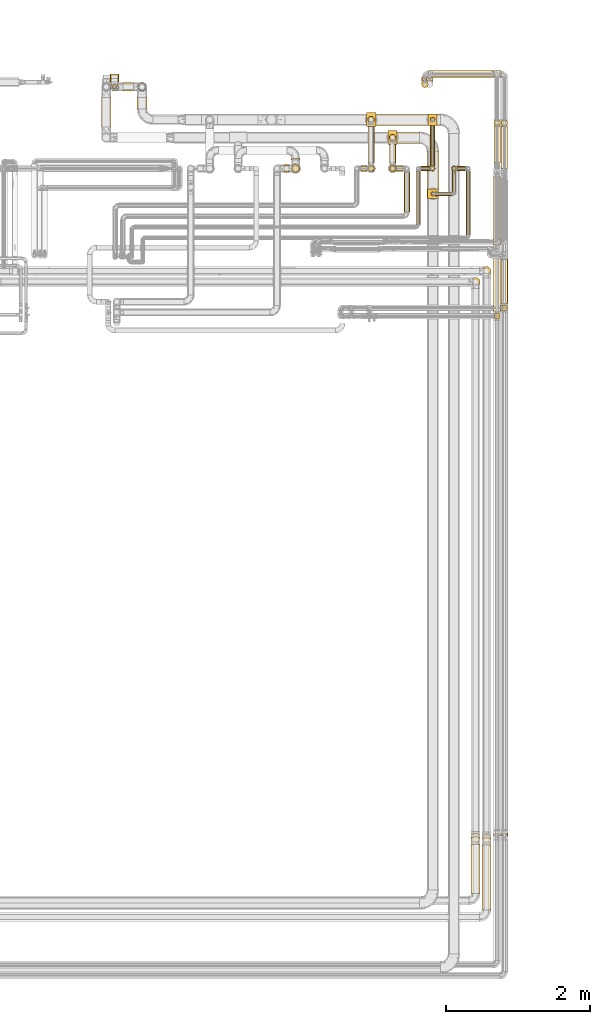
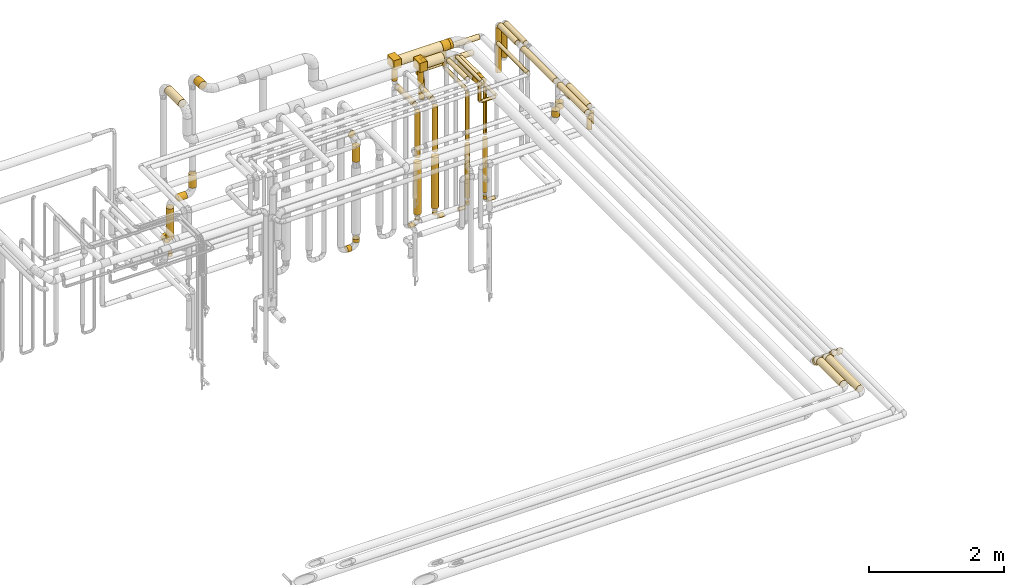
# One storey, part 18 of 824: 70 coverings.
"""IFC2X3 building model written with IfcOpenShell, lengths in millimetres."""

from ifc_helpers import new_model, entity, si_unit, converted_unit, derived_unit, direction, frame, frame_2d, origin, origin_2d_with_axis, place, context, subcontext, project, spatial, polyline, circle_curve, parameter, trimmed, segment, composite_curve, rectangle, circle, outline, extrude, element, save


model = new_model("IFC2X3")

# Units and contexts
model_context = context("Model", 3, precision=0.01, world=origin(), true_north=direction((6.12303176911189e-17, 1.0)))
body_context = subcontext(model_context, "Body", "Model", "MODEL_VIEW")
ifc_project = project(units=[si_unit("LENGTHUNIT", "METRE", prefix="MILLI"), si_unit("AREAUNIT", "SQUARE_METRE"), si_unit("VOLUMEUNIT", "CUBIC_METRE"), converted_unit("PLANEANGLEUNIT", "DEGREE", entity("IfcRatioMeasure", 0.0174532925199433), si_unit("PLANEANGLEUNIT", "RADIAN"), dimensions=[0, 0, 0, 0, 0, 0, 0]), si_unit("MASSUNIT", "GRAM", prefix="KILO"), derived_unit("MASSDENSITYUNIT", [(si_unit("MASSUNIT", "GRAM", prefix="KILO"), 1), (si_unit("LENGTHUNIT", "METRE"), -3)]), derived_unit("MOMENTOFINERTIAUNIT", [(si_unit("LENGTHUNIT", "METRE"), 4)]), si_unit("TIMEUNIT", "SECOND"), si_unit("FREQUENCYUNIT", "HERTZ"), si_unit("THERMODYNAMICTEMPERATUREUNIT", "DEGREE_CELSIUS"), derived_unit("THERMALTRANSMITTANCEUNIT", [(si_unit("MASSUNIT", "GRAM", prefix="KILO"), 1), (si_unit("THERMODYNAMICTEMPERATUREUNIT", "KELVIN"), -1), (si_unit("TIMEUNIT", "SECOND"), -3)]), derived_unit("VOLUMETRICFLOWRATEUNIT", [(si_unit("LENGTHUNIT", "METRE"), 3), (si_unit("TIMEUNIT", "SECOND"), -1)]), derived_unit("MASSFLOWRATEUNIT", [(si_unit("MASSUNIT", "GRAM", prefix="KILO"), 1), (si_unit("TIMEUNIT", "SECOND"), -1)]), derived_unit("ROTATIONALFREQUENCYUNIT", [(si_unit("TIMEUNIT", "SECOND"), -1)]), si_unit("ELECTRICCURRENTUNIT", "AMPERE"), si_unit("ELECTRICVOLTAGEUNIT", "VOLT"), si_unit("POWERUNIT", "WATT"), si_unit("FORCEUNIT", "NEWTON", prefix="KILO"), si_unit("ILLUMINANCEUNIT", "LUX"), si_unit("LUMINOUSFLUXUNIT", "LUMEN"), si_unit("LUMINOUSINTENSITYUNIT", "CANDELA"), derived_unit("USERDEFINED", [(si_unit("MASSUNIT", "GRAM", prefix="KILO"), -1), (si_unit("LENGTHUNIT", "METRE"), -2), (si_unit("TIMEUNIT", "SECOND"), 3), (si_unit("LUMINOUSFLUXUNIT", "LUMEN"), 1)]), derived_unit("LINEARVELOCITYUNIT", [(si_unit("LENGTHUNIT", "METRE"), 1), (si_unit("TIMEUNIT", "SECOND"), -1)]), si_unit("PRESSUREUNIT", "PASCAL"), derived_unit("USERDEFINED", [(si_unit("LENGTHUNIT", "METRE"), -2), (si_unit("MASSUNIT", "GRAM", prefix="KILO"), 1), (si_unit("TIMEUNIT", "SECOND"), -2)]), derived_unit("LINEARFORCEUNIT", [(si_unit("MASSUNIT", "GRAM", prefix="KILO"), 1), (si_unit("LENGTHUNIT", "METRE"), 1), (si_unit("TIMEUNIT", "SECOND"), -2), (si_unit("LENGTHUNIT", "METRE"), -1)]), derived_unit("PLANARFORCEUNIT", [(si_unit("MASSUNIT", "GRAM", prefix="KILO"), 1), (si_unit("LENGTHUNIT", "METRE"), 1), (si_unit("TIMEUNIT", "SECOND"), -2), (si_unit("LENGTHUNIT", "METRE"), -2)])], contexts=[model_context])

# Site, building, storey
site_placement = place(None, origin())
site = spatial("IfcSite", under=ifc_project, at=site_placement, CompositionType="ELEMENT")
building_placement = place(site_placement, origin())
building = spatial("IfcBuilding", under=site, at=building_placement, CompositionType="ELEMENT")
storey_placement = place(building_placement, frame((0.0, 0.0, 28200.0)))
storey = spatial("IfcBuildingStorey", under=building, at=storey_placement, CompositionType="ELEMENT", Elevation=28200.0)

# Coverings
covering_1_placement = place(storey_placement, frame((60838.76, 16008.03, 2795.04)))
element("IfcCovering", 1, at=covering_1_placement, inside=storey, PredefinedType="INSULATION", context=body_context, shape_type="SweptSolid", body=[
    extrude(circle(Radius=62.75, at=origin_2d_with_axis()), frame((64.35, 64.35, 0.0)), (0.0, 0.0, 1.0), 109.962845985803),
])
covering_2_placement = place(storey_placement, frame((59550.07, 17576.0, 2448.15)))
element("IfcCovering", 2, at=covering_2_placement, inside=storey, PredefinedType="INSULATION", context=body_context, shape_type="SweptSolid", body=[
    extrude(circle(Radius=45.0, at=origin_2d_with_axis()), frame((46.6, 0.0, 46.6), z_axis=(0.0, 1.0, 0.0), x_axis=(1.0, 0.0, 0.0)), (0.0, 0.0, 1.0), 278.096097794324),
])
covering_3_placement = place(storey_placement, frame((59550.07, 17453.4, 1602.24)))
element("IfcCovering", 3, at=covering_3_placement, inside=storey, PredefinedType="INSULATION", context=body_context, shape_type="SweptSolid", body=[
    extrude(circle(Radius=45.0, at=origin_2d_with_axis()), frame((46.6, 46.6, 0.0), z_axis=(0.0, 0.0, 1.0), x_axis=(0.0, 1.0, 0.0)), (0.0, 0.0, 1.0), 816.499999999996),
])
covering_4_placement = place(storey_placement, frame((60128.55, 17117.79, 2531.09)))
element("IfcCovering", 4, at=covering_4_placement, inside=storey, PredefinedType="INSULATION", context=body_context, shape_type="SweptSolid", body=[
    extrude(circle(Radius=28.4, at=origin_2d_with_axis()), frame((30.0, 30.0, 0.0), z_axis=(-1.46203474159763e-05, 0.0, 1.0), x_axis=(0.0, 1.0, 0.0)), (0.0, 0.0, 1.0), 298.905011104185),
])
covering_5_placement = place(storey_placement, frame((60075.45, 17212.79, 2816.87)))
element("IfcCovering", 5, at=covering_5_placement, inside=storey, PredefinedType="INSULATION", context=body_context, shape_type="SweptSolid", body=[
    extrude(circle(Radius=81.5, at=origin_2d_with_axis()), frame((83.1, 0.0, 83.1), z_axis=(0.0, 1.0, 0.0), x_axis=(1.0, 0.0, 0.0)), (0.0, 0.0, 1.0), 527.308325226667),
])
covering_6_placement = place(storey_placement, frame((60187.65, 17117.79, 2472.0)))
element("IfcCovering", 6, at=covering_6_placement, inside=storey, PredefinedType="INSULATION", context=body_context, shape_type="SweptSolid", body=[
    extrude(circle(Radius=28.4, at=origin_2d_with_axis()), frame((0.0, 30.0, 30.0), z_axis=(1.0, 0.0, 0.0), x_axis=(0.0, 1.0, 0.0)), (0.0, 0.0, 1.0), 237.633062103833),
])
covering_7_placement = place(storey_placement, frame((60424.39, 17176.89, 2472.0)))
element("IfcCovering", 7, at=covering_7_placement, inside=storey, PredefinedType="INSULATION", context=body_context, shape_type="SweptSolid", body=[
    extrude(circle(Radius=28.4, at=origin_2d_with_axis()), frame((30.0, 0.0, 30.0), z_axis=(0.0, 1.0, 0.0), x_axis=(-1.0, 0.0, 0.0)), (0.0, 0.0, 1.0), 294.012227432359),
])
covering_8_placement = place(storey_placement, frame((60424.39, 17470.0, 1600.0)))
element("IfcCovering", 8, at=covering_8_placement, inside=storey, PredefinedType="INSULATION", context=body_context, shape_type="SweptSolid", body=[
    extrude(circle(Radius=28.4, at=origin_2d_with_axis()), frame((30.0, 30.0, 0.0), z_axis=(0.0, 0.0, 1.0), x_axis=(-1.0, 0.0, 0.0)), (0.0, 0.0, 1.0), 872.894988927772),
])
covering_9_placement = place(storey_placement, frame((61004.89, 17573.83, 2952.0)))
element("IfcCovering", 9, at=covering_9_placement, inside=storey, PredefinedType="INSULATION", context=body_context, shape_type="SweptSolid", body=[
    extrude(circle(Radius=46.15, at=origin_2d_with_axis()), frame((47.75, 0.0, 47.75), z_axis=(0.0, 1.0, 0.0), x_axis=(-1.0, 0.0, 0.0)), (0.0, 0.0, 1.0), 515.500000000028),
])
covering_10_placement = place(storey_placement, frame((61004.89, 18089.59, 2137.37)))
element("IfcCovering", 10, at=covering_10_placement, inside=storey, PredefinedType="INSULATION", context=body_context, shape_type="SweptSolid", body=[
    extrude(circle(Radius=46.15, at=origin_2d_with_axis()), frame((47.75, 47.75, 0.0), z_axis=(0.0, 0.0, 1.0), x_axis=(0.0, 1.0, 0.0)), (0.0, 0.0, 1.0), 814.370023810611),
])
covering_11_placement = place(storey_placement, frame((61002.04, 16436.84, 2949.15)))
element("IfcCovering", 11, at=covering_11_placement, inside=storey, PredefinedType="INSULATION", context=body_context, shape_type="SweptSolid", body=[
    extrude(circle(Radius=49.0, at=origin_2d_with_axis()), frame((50.6, 0.0, 50.6), z_axis=(0.0, 1.0, 0.0), x_axis=(1.0, 0.0, 0.0)), (0.0, 0.0, 1.0), 958.995662655606),
])
covering_12_placement = place(storey_placement, frame((61002.04, 15501.21, 2949.15)))
element("IfcCovering", 12, at=covering_12_placement, inside=storey, PredefinedType="INSULATION", context=body_context, shape_type="SweptSolid", body=[
    extrude(circle(Radius=49.0, at=origin_2d_with_axis()), frame((50.6, 0.0, 50.6), z_axis=(0.0, 1.0, 0.0), x_axis=(-1.0, 0.0, 0.0)), (0.0, 0.0, 1.0), 821.627947057632),
])
covering_13_placement = place(storey_placement, frame((61009.29, 15400.86, 2738.0)))
element("IfcCovering", 13, at=covering_13_placement, inside=storey, PredefinedType="INSULATION", context=body_context, shape_type="SweptSolid", body=[
    extrude(circle(Radius=41.75, at=origin_2d_with_axis()), frame((43.35, 43.35, 0.0), z_axis=(0.0, 0.0, 1.0), x_axis=(0.0, -1.0, 0.0)), (0.0, 0.0, 1.0), 204.743188805694),
])
covering_14_placement = place(storey_placement, frame((61104.89, 17500.83, 2952.0)))
element("IfcCovering", 14, at=covering_14_placement, inside=storey, PredefinedType="INSULATION", context=body_context, shape_type="SweptSolid", body=[
    extrude(circle(Radius=46.15, at=origin_2d_with_axis()), frame((47.75, 0.0, 47.75), z_axis=(0.0, 1.0, 0.0), x_axis=(-1.0, 0.0, 0.0)), (0.0, 0.0, 1.0), 585.000000000008),
])
covering_15_placement = place(storey_placement, frame((61102.04, 15617.52, 2949.15)))
element("IfcCovering", 15, at=covering_15_placement, inside=storey, PredefinedType="INSULATION", context=body_context, shape_type="SweptSolid", body=[
    extrude(circle(Radius=49.0, at=origin_2d_with_axis()), frame((50.6, 0.0, 50.6), z_axis=(0.0, 1.0, 0.0), x_axis=(-1.0, 0.0, 0.0)), (0.0, 0.0, 1.0), 614.353457594442),
])
covering_16_placement = place(storey_placement, frame((61109.29, 15517.18, 2738.0)))
element("IfcCovering", 16, at=covering_16_placement, inside=storey, PredefinedType="INSULATION", context=body_context, shape_type="SweptSolid", body=[
    extrude(circle(Radius=41.75, at=origin_2d_with_axis()), frame((43.35, 43.35, 0.0), z_axis=(0.0, 0.0, 1.0), x_axis=(0.0, -1.0, 0.0)), (0.0, 0.0, 1.0), 204.743188805685),
])
covering_17_placement = place(storey_placement, frame((55540.45, 18080.1, 3429.4)))
element("IfcCovering", 17, at=covering_17_placement, inside=storey, PredefinedType="INSULATION", context=body_context, shape_type="SweptSolid", body=[
    extrude(circle(Radius=69.0, at=origin_2d_with_axis()), frame((70.6, 0.0, 70.6), z_axis=(0.0, 1.0, 0.0), x_axis=(-1.0, 0.0, 0.0)), (0.0, 0.0, 1.0), 405.890503073728),
])
covering_18_placement = place(storey_placement, frame((59550.07, 17883.5, 2570.74)))
element("IfcCovering", 18, at=covering_18_placement, inside=storey, PredefinedType="INSULATION", context=body_context, shape_type="SweptSolid", body=[
    extrude(circle(Radius=45.0, at=origin_2d_with_axis()), frame((46.6, 46.6, 0.0)), (0.0, 0.0, 1.0), 259.256811194313),
])
covering_19_placement = place(storey_placement, frame((59531.67, 17833.85, 2830.0)))
element("IfcCovering", 19, at=covering_19_placement, inside=storey, PredefinedType="INSULATION", context=body_context, shape_type="SweptSolid", body=[
    extrude(rectangle(XDim=129.999999999996, YDim=192.500000000002, at=origin_2d_with_axis()), frame((65.0, 96.25, 0.0), z_axis=(0.0, 0.0, 1.0), x_axis=(-1.0, 0.0, 0.0)), (0.0, 0.0, 1.0), 166.25000000001),
])
covering_20_placement = place(storey_placement, frame((59661.67, 17847.0, 2816.87)))
element("IfcCovering", 20, at=covering_20_placement, inside=storey, PredefinedType="INSULATION", context=body_context, shape_type="SweptSolid", body=[
    extrude(circle(Radius=81.5, at=origin_2d_with_axis()), frame((0.0, 83.1, 83.1), z_axis=(1.0, 0.0, 0.0), x_axis=(0.0, -1.0, 0.0)), (0.0, 0.0, 1.0), 306.875508273996),
])
covering_21_placement = place(storey_placement, frame((60161.17, 18768.35, 2287.0)))
element("IfcCovering", 21, at=covering_21_placement, inside=storey, PredefinedType="INSULATION", context=body_context, shape_type="SweptSolid", body=[
    extrude(circle(Radius=46.15, at=origin_2d_with_axis()), frame((0.0, 47.75, 47.75), z_axis=(1.0, 0.0, 0.0), x_axis=(0.0, -1.0, 0.0)), (0.0, 0.0, 1.0), 943.465172144308),
])
covering_22_placement = place(storey_placement, frame((60096.17, 18768.2, 2041.63)))
element("IfcCovering", 22, at=covering_22_placement, inside=storey, PredefinedType="INSULATION", context=body_context, shape_type="SweptSolid", body=[
    extrude(circle(Radius=46.15, at=origin_2d_with_axis()), frame((0.01, 47.89, 47.75), z_axis=(0.999999986826571, -0.000162317151743365, 0.0), x_axis=(-0.000162317151743365, -0.999999986826571, 0.0)), (0.0, 0.0, 1.0), 908.465194111927),
])
covering_23_placement = place(storey_placement, frame((60065.43, 18719.47, 2287.0)))
element("IfcCovering", 23, at=covering_23_placement, inside=storey, PredefinedType="INSULATION", context=body_context, shape_type="SweptSolid", body=[
    extrude(circle(Radius=46.15, at=origin_2d_with_axis()), frame((47.75, 0.0, 47.75), z_axis=(0.0, 1.0, 0.0), x_axis=(-1.0, 0.0, 0.0)), (0.0, 0.0, 1.0), 48.6274645694443),
])
covering_24_placement = place(storey_placement, frame((60000.43, 18623.72, 1689.87)))
element("IfcCovering", 24, at=covering_24_placement, inside=storey, PredefinedType="INSULATION", context=body_context, shape_type="SweptSolid", body=[
    extrude(circle(Radius=46.15, at=origin_2d_with_axis()), frame((47.75, 47.75, 0.0), z_axis=(0.0, 0.0, 1.0), x_axis=(0.0, -1.0, 0.0)), (0.0, 0.0, 1.0), 351.500000000011),
])
covering_25_placement = place(storey_placement, frame((60000.43, 18719.47, 2041.63)))
element("IfcCovering", 25, at=covering_25_placement, inside=storey, PredefinedType="INSULATION", context=body_context, shape_type="SweptSolid", body=[
    extrude(circle(Radius=46.15, at=origin_2d_with_axis()), frame((47.75, 0.0, 47.75), z_axis=(0.0, 1.0, 0.0), x_axis=(-1.0, 0.0, 0.0)), (0.0, 0.0, 1.0), 48.6274645694486),
])
covering_26_placement = place(storey_placement, frame((59757.54, 16894.94, 3159.4)))
element("IfcCovering", 26, at=covering_26_placement, inside=storey, PredefinedType="INSULATION", context=body_context, shape_type="SweptSolid", body=[
    extrude(circle(Radius=39.0, at=origin_2d_with_axis()), frame((40.6, 0.0, 40.6), z_axis=(0.0, 1.0, 0.0), x_axis=(1.0, 0.0, 0.0)), (0.0, 0.0, 1.0), 548.064099051886),
])
covering_27_placement = place(storey_placement, frame((59653.67, 17459.4, 359.4)))
element("IfcCovering", 27, at=covering_27_placement, inside=storey, PredefinedType="INSULATION", context=body_context, shape_type="SweptSolid", body=[
    extrude(circle(Radius=39.0, at=origin_2d_with_axis()), frame((0.0, 40.6, 40.6), z_axis=(1.0, 0.0, 0.0), x_axis=(0.0, -1.0, 0.0)), (0.0, 0.0, 1.0), 87.4629414974364),
])
covering_28_placement = place(storey_placement, frame((59556.07, 17459.4, 457.0)))
element("IfcCovering", 28, at=covering_28_placement, inside=storey, PredefinedType="INSULATION", context=body_context, shape_type="SweptSolid", body=[
    extrude(circle(Radius=39.0, at=origin_2d_with_axis()), frame((40.6, 40.6, 0.0)), (0.0, 0.0, 1.0), 43.0000000000076),
])
covering_29_placement = place(storey_placement, frame((60492.38, 17466.65, 366.65)))
element("IfcCovering", 29, at=covering_29_placement, inside=storey, PredefinedType="INSULATION", context=body_context, shape_type="SweptSolid", body=[
    extrude(circle(Radius=31.75, at=origin_2d_with_axis()), frame((0.0, 33.35, 33.35), z_axis=(1.0, 0.0, 0.0), x_axis=(0.0, -1.0, 0.0)), (0.0, 0.0, 1.0), 122.750000000028),
])
covering_30_placement = place(storey_placement, frame((60421.04, 17466.65, 438.0)))
element("IfcCovering", 30, at=covering_30_placement, inside=storey, PredefinedType="INSULATION", context=body_context, shape_type="SweptSolid", body=[
    extrude(circle(Radius=31.75, at=origin_2d_with_axis()), frame((33.35, 33.35, 0.0)), (0.0, 0.0, 1.0), 62.0000000000162),
])
covering_31_placement = place(storey_placement, frame((60619.79, 16573.69, 3166.65)))
element("IfcCovering", 31, at=covering_31_placement, inside=storey, PredefinedType="INSULATION", context=body_context, shape_type="SweptSolid", body=[
    extrude(circle(Radius=31.75, at=origin_2d_with_axis()), frame((33.35, 0.0, 33.35), z_axis=(0.0, 1.0, 0.0), x_axis=(1.0, 0.0, 0.0)), (0.0, 0.0, 1.0), 888.304686356007),
])
covering_32_placement = place(storey_placement, frame((59535.82, 17439.15, 589.0)))
element("IfcCovering", 32, at=covering_32_placement, inside=storey, PredefinedType="INSULATION", context=body_context, shape_type="SweptSolid", body=[
    extrude(circle(Radius=59.25, at=origin_2d_with_axis()), frame((60.85, 60.85, 0.0), z_axis=(0.0, 0.0, 1.0), x_axis=(-1.0, 0.0, 0.0)), (0.0, 0.0, 1.0), 924.243188805704),
])
covering_33_placement = place(storey_placement, frame((60413.79, 17459.4, 564.0)))
element("IfcCovering", 33, at=covering_33_placement, inside=storey, PredefinedType="INSULATION", context=body_context, shape_type="SweptSolid", body=[
    extrude(circle(Radius=39.0, at=origin_2d_with_axis()), frame((40.6, 40.6, 0.0)), (0.0, 0.0, 1.0), 971.999999999987),
])
covering_34_placement = place(storey_placement, frame((61102.04, 8156.92, 2980.19)))
element("IfcCovering", 34, at=covering_34_placement, inside=storey, PredefinedType="INSULATION", context=body_context, shape_type="SweptSolid", body=[
    extrude(circle(Radius=49.0, at=origin_2d_with_axis()), frame((50.6, 103.11, 36.24), z_axis=(0.0, -0.707106781186542, 0.707106781186553), x_axis=(1.0, 0.0, 0.0)), (0.0, 0.0, 1.0), 94.5641960007415),
])
covering_35_placement = place(storey_placement, frame((61002.04, 8157.83, 2980.19)))
element("IfcCovering", 35, at=covering_35_placement, inside=storey, PredefinedType="INSULATION", context=body_context, shape_type="SweptSolid", body=[
    extrude(circle(Radius=49.0, at=origin_2d_with_axis()), frame((50.6, 103.11, 36.24), z_axis=(0.0, -0.707106781186546, 0.707106781186549), x_axis=(1.0, 0.0, 0.0)), (0.0, 0.0, 1.0), 94.5641960007307),
])
covering_36_placement = place(storey_placement, frame((60838.76, 7175.0, 3035.65)))
element("IfcCovering", 36, at=covering_36_placement, inside=storey, PredefinedType="INSULATION", context=body_context, shape_type="SweptSolid", body=[
    extrude(circle(Radius=62.75, at=origin_2d_with_axis()), frame((64.35, 0.0, 64.35), z_axis=(0.0, 1.0, 0.0), x_axis=(-1.0, 0.0, 0.0)), (0.0, 0.0, 1.0), 906.837013694414),
])
covering_37_placement = place(storey_placement, frame((60838.76, 8103.05, 2981.86)))
element("IfcCovering", 37, at=covering_37_placement, inside=storey, PredefinedType="INSULATION", context=body_context, shape_type="SweptSolid", body=[
    extrude(circle(Radius=62.75, at=origin_2d_with_axis()), frame((64.35, 90.32, 45.97), z_axis=(0.0, -0.707106781186538, 0.707106781186557), x_axis=(1.0, 0.0, 0.0)), (0.0, 0.0, 1.0), 62.7207793864224),
])
covering_38_placement = place(storey_placement, frame((56037.95, 18330.1, 3429.15)))
element("IfcCovering", 38, at=covering_38_placement, inside=storey, PredefinedType="INSULATION", context=body_context, shape_type="SweptSolid", body=[
    extrude(circle(Radius=69.0, at=origin_2d_with_axis()), frame((70.6, 0.0, 70.6), z_axis=(0.0, 1.0, 0.0), x_axis=(-1.0, 0.0, 0.0)), (0.0, 0.0, 1.0), 155.890486759072),
])
covering_39_placement = place(storey_placement, frame((55845.5, 18574.89, 1312.79)))
element("IfcCovering", 39, at=covering_39_placement, inside=storey, PredefinedType="INSULATION", context=body_context, shape_type="SweptSolid", body=[
    extrude(circle(Radius=59.5, at=origin_2d_with_axis()), frame((0.0, 61.1, 61.1), z_axis=(1.0, 0.0, 0.0), x_axis=(0.0, -1.0, 0.0)), (0.0, 0.0, 1.0), 143.048447506268),
])
covering_40_placement = place(storey_placement, frame((55664.4, 18705.99, 554.4)))
element("IfcCovering", 40, at=covering_40_placement, inside=storey, PredefinedType="INSULATION", context=body_context, shape_type="SweptSolid", body=[
    extrude(circle(Radius=59.5, at=origin_2d_with_axis()), frame((61.1, 0.0, 61.1), z_axis=(0.0, 1.0, 0.0), x_axis=(-1.0, 0.0, 0.0)), (0.0, 0.0, 1.0), 49.9999999999995),
])
covering_41_placement = place(storey_placement, frame((55664.4, 18574.89, 695.5)))
element("IfcCovering", 41, at=covering_41_placement, inside=storey, PredefinedType="INSULATION", context=body_context, shape_type="SweptSolid", body=[
    extrude(circle(Radius=59.5, at=origin_2d_with_axis()), frame((61.1, 61.1, 0.0), z_axis=(0.0, 0.0, 1.0), x_axis=(0.0, 1.0, 0.0)), (0.0, 0.0, 1.0), 558.388760911339),
])
covering_42_placement = place(storey_placement, frame((58186.72, 17620.0, 2239.15)))
element("IfcCovering", 42, at=covering_42_placement, inside=storey, PredefinedType="INSULATION", context=body_context, shape_type="SweptSolid", body=[
    extrude(circle(Radius=59.25, at=origin_2d_with_axis()), frame((60.85, 0.0, 60.85), z_axis=(0.0, 1.0, 0.0), x_axis=(1.0, 0.0, 0.0)), (0.0, 0.0, 1.0), 15.0961141089939),
])
covering_43_placement = place(storey_placement, frame((58186.72, 17439.15, 1902.45)))
element("IfcCovering", 43, at=covering_43_placement, inside=storey, PredefinedType="INSULATION", context=body_context, shape_type="SweptSolid", body=[
    extrude(circle(Radius=59.25, at=origin_2d_with_axis()), frame((60.85, 60.85, 0.0), z_axis=(0.0, 0.0, 1.0), x_axis=(-1.0, 0.0, 0.0)), (0.0, 0.0, 1.0), 277.547222472813),
])
covering_44_placement = place(storey_placement, frame((59251.3, 18133.5, 2577.24)))
element("IfcCovering", 44, at=covering_44_placement, inside=storey, PredefinedType="INSULATION", context=body_context, shape_type="SweptSolid", body=[
    extrude(circle(Radius=45.0, at=origin_2d_with_axis()), frame((46.6, 46.6, 0.0)), (0.0, 0.0, 1.0), 252.756811194297),
])
covering_45_placement = place(storey_placement, frame((59232.89, 18083.85, 2830.0)))
element("IfcCovering", 45, at=covering_45_placement, inside=storey, PredefinedType="INSULATION", context=body_context, shape_type="SweptSolid", body=[
    extrude(rectangle(XDim=129.999999999996, YDim=192.500000000002, at=origin_2d_with_axis()), frame((65.0, 96.25, 0.0), z_axis=(0.0, 0.0, 1.0), x_axis=(-1.0, 0.0, 0.0)), (0.0, 0.0, 1.0), 166.25000000001),
])
covering_46_placement = place(storey_placement, frame((59362.89, 18097.0, 2816.9)))
element("IfcCovering", 46, at=covering_46_placement, inside=storey, PredefinedType="INSULATION", context=body_context, shape_type="SweptSolid", body=[
    extrude(circle(Radius=81.5, at=origin_2d_with_axis()), frame((0.0, 83.1, 83.1), z_axis=(1.0, 0.0, 0.0), x_axis=(0.0, -1.0, 0.0)), (0.0, 0.0, 1.0), 725.240640582081),
])
covering_47_placement = place(storey_placement, frame((59251.3, 17575.0, 2455.65)))
element("IfcCovering", 47, at=covering_47_placement, inside=storey, PredefinedType="INSULATION", context=body_context, shape_type="SweptSolid", body=[
    extrude(circle(Radius=45.0, at=origin_2d_with_axis()), frame((46.6, 0.0, 46.6), z_axis=(0.0, 1.0, 0.0), x_axis=(1.0, 0.0, 0.0)), (0.0, 0.0, 1.0), 530.096114108994),
])
covering_48_placement = place(storey_placement, frame((59251.3, 17453.4, 1602.24)))
element("IfcCovering", 48, at=covering_48_placement, inside=storey, PredefinedType="INSULATION", context=body_context, shape_type="SweptSolid", body=[
    extrude(circle(Radius=45.0, at=origin_2d_with_axis()), frame((46.6, 46.6, 0.0), z_axis=(0.0, 0.0, 1.0), x_axis=(0.0, 1.0, 0.0)), (0.0, 0.0, 1.0), 825.000000000016),
])
covering_49_placement = place(storey_placement, frame((60119.79, 17538.0, 2466.65)))
element("IfcCovering", 49, at=covering_49_placement, inside=storey, PredefinedType="INSULATION", context=body_context, shape_type="SweptSolid", body=[
    extrude(circle(Radius=31.75, at=origin_2d_with_axis()), frame((33.35, 0.0, 33.35), z_axis=(0.0, 1.0, 0.0), x_axis=(1.0, 0.0, 0.0)), (0.0, 0.0, 1.0), 604.096114108988),
])
covering_50_placement = place(storey_placement, frame((60119.79, 18146.75, 2538.0)))
element("IfcCovering", 50, at=covering_50_placement, inside=storey, PredefinedType="INSULATION", context=body_context, shape_type="SweptSolid", body=[
    extrude(circle(Radius=31.75, at=origin_2d_with_axis()), frame((33.35, 33.35, 0.0), z_axis=(0.0, 0.0, 1.0), x_axis=(0.0, -1.0, 0.0)), (0.0, 0.0, 1.0), 291.999999999986),
])
covering_51_placement = place(storey_placement, frame((60218.13, 18097.0, 2816.9)))
element("IfcCovering", 51, at=covering_51_placement, inside=storey, PredefinedType="INSULATION", context=body_context, shape_type="SweptSolid", body=[
    extrude(circle(Radius=81.5, at=origin_2d_with_axis()), frame((0.0, 83.1, 83.1), z_axis=(1.0, 0.0, 0.0), x_axis=(0.0, -1.0, 0.0)), (0.0, 0.0, 1.0), 42.9168860607221),
])
covering_52_placement = place(storey_placement, frame((60119.79, 17466.65, 1600.0)))
element("IfcCovering", 52, at=covering_52_placement, inside=storey, PredefinedType="INSULATION", context=body_context, shape_type="SweptSolid", body=[
    extrude(circle(Radius=31.75, at=origin_2d_with_axis()), frame((33.35, 33.35, 0.0), z_axis=(0.0, 0.0, 1.0), x_axis=(0.0, -1.0, 0.0)), (0.0, 0.0, 1.0), 862.000000000012),
])
covering_53_placement = place(storey_placement, frame((59991.13, 17466.65, 366.65)))
element("IfcCovering", 53, at=covering_53_placement, inside=storey, PredefinedType="INSULATION", context=body_context, shape_type="SweptSolid", body=[
    extrude(circle(Radius=31.75, at=origin_2d_with_axis()), frame((0.0, 33.35, 33.35), z_axis=(1.0, 0.0, 0.0), x_axis=(0.0, 1.0, 0.0)), (0.0, 0.0, 1.0), 124.000000000015),
])
covering_54_placement = place(storey_placement, frame((60119.79, 17466.65, 438.0)))
element("IfcCovering", 54, at=covering_54_placement, inside=storey, PredefinedType="INSULATION", context=body_context, shape_type="SweptSolid", body=[
    extrude(circle(Radius=31.75, at=origin_2d_with_axis()), frame((33.35, 33.35, 0.0)), (0.0, 0.0, 1.0), 62.0000000000119),
])
covering_55_placement = place(storey_placement, frame((59155.13, 17459.4, 359.4)))
element("IfcCovering", 55, at=covering_55_placement, inside=storey, PredefinedType="INSULATION", context=body_context, shape_type="SweptSolid", body=[
    extrude(circle(Radius=39.0, at=origin_2d_with_axis()), frame((0.0, 40.6, 40.6), z_axis=(1.0, 0.0, 0.0), x_axis=(0.0, 1.0, 0.0)), (0.0, 0.0, 1.0), 86.0000000000064),
])
covering_56_placement = place(storey_placement, frame((59257.3, 17459.4, 457.0)))
element("IfcCovering", 56, at=covering_56_placement, inside=storey, PredefinedType="INSULATION", context=body_context, shape_type="SweptSolid", body=[
    extrude(circle(Radius=39.0, at=origin_2d_with_axis()), frame((40.6, 40.6, 0.0)), (0.0, 0.0, 1.0), 33.0000000000055),
])
covering_57_placement = place(storey_placement, frame((58082.89, 17445.65, 295.65)))
element("IfcCovering", 57, at=covering_57_placement, inside=storey, PredefinedType="INSULATION", context=body_context, shape_type="SweptSolid", body=[
    extrude(circle(Radius=52.75, at=origin_2d_with_axis()), frame((0.0, 54.35, 54.35), z_axis=(1.0, 0.0, 0.0), x_axis=(0.0, 1.0, 0.0)), (0.0, 0.0, 1.0), 69.6845769329227),
])
covering_58_placement = place(storey_placement, frame((58193.22, 17445.65, 445.0)))
element("IfcCovering", 58, at=covering_58_placement, inside=storey, PredefinedType="INSULATION", context=body_context, shape_type="SweptSolid", body=[
    extrude(circle(Radius=52.75, at=origin_2d_with_axis()), frame((54.35, 54.35, 0.0)), (0.0, 0.0, 1.0), 55.0000000000005),
])
covering_59_placement = place(storey_placement, frame((59919.79, 16723.69, 3166.65)))
element("IfcCovering", 59, at=covering_59_placement, inside=storey, PredefinedType="INSULATION", context=body_context, shape_type="SweptSolid", body=[
    extrude(circle(Radius=31.75, at=origin_2d_with_axis()), frame((33.35, 0.0, 33.35), z_axis=(0.0, 1.0, 0.0), x_axis=(1.0, 0.0, 0.0)), (0.0, 0.0, 1.0), 738.30468635603),
])
covering_60_placement = place(storey_placement, frame((56047.45, 18574.89, 1493.89)))
element("IfcCovering", 60, at=covering_60_placement, inside=storey, PredefinedType="INSULATION", context=body_context, shape_type="SweptSolid", body=[
    extrude(circle(Radius=59.5, at=origin_2d_with_axis()), frame((61.1, 61.1, 0.0), z_axis=(0.0, 0.0, 1.0), x_axis=(-1.0, 0.0, 0.0)), (0.0, 0.0, 1.0), 231.111239088707),
])
covering_61_placement = place(storey_placement, frame((55691.4, 18601.89, 369.5)))
element("IfcCovering", 61, at=covering_61_placement, inside=storey, PredefinedType="INSULATION", context=body_context, shape_type="SweptSolid", body=[
    extrude(circle(Radius=32.5, at=origin_2d_with_axis()), frame((34.1, 34.1, 0.0), z_axis=(0.0, 0.0, 1.0), x_axis=(0.0, 1.0, 0.0)), (0.0, 0.0, 1.0), 61.0000000000035),
])
covering_62_placement = place(storey_placement, frame((55664.4, 18755.99, 554.4)))
element("IfcCovering", 62, at=covering_62_placement, inside=storey, PredefinedType="INSULATION", context=body_context, shape_type="SweptSolid", body=[
    extrude(circle(Radius=59.5, at=origin_2d_with_axis()), frame((61.1, 0.0, 61.1), z_axis=(0.0, 1.0, 0.0), x_axis=(-1.0, 0.0, 0.0)), (0.0, 0.0, 1.0), 59.9999999999994),
])
covering_63_placement = place(storey_placement, frame((59237.05, 17439.15, 579.0)))
element("IfcCovering", 63, at=covering_63_placement, inside=storey, PredefinedType="INSULATION", context=body_context, shape_type="SweptSolid", body=[
    extrude(circle(Radius=59.25, at=origin_2d_with_axis()), frame((60.85, 60.85, 0.0), z_axis=(0.0, 0.0, 1.0), x_axis=(-1.0, 0.0, 0.0)), (0.0, 0.0, 1.0), 934.243188805697),
])
covering_64_placement = place(storey_placement, frame((60112.54, 17459.4, 564.0)))
element("IfcCovering", 64, at=covering_64_placement, inside=storey, PredefinedType="INSULATION", context=body_context, shape_type="SweptSolid", body=[
    extrude(circle(Radius=39.0, at=origin_2d_with_axis()), frame((40.6, 40.6, 0.0), z_axis=(0.0, 0.0, 1.0), x_axis=(-1.0, 0.0, 0.0)), (0.0, 0.0, 1.0), 971.999999999991),
])
covering_65_placement = place(storey_placement, frame((60688.76, 15858.03, 2795.0)))
element("IfcCovering", 65, at=covering_65_placement, inside=storey, PredefinedType="INSULATION", context=body_context, shape_type="SweptSolid", body=[
    extrude(circle(Radius=62.75, at=origin_2d_with_axis()), frame((64.35, 64.35, 0.0), z_axis=(0.0, 0.0, 1.0), x_axis=(0.0, -1.0, 0.0)), (0.0, 0.0, 1.0), 110.000000000049),
])
covering_66_placement = place(storey_placement, frame((60688.76, 7405.0, 3035.65)))
element("IfcCovering", 66, at=covering_66_placement, inside=storey, PredefinedType="INSULATION", context=body_context, shape_type="SweptSolid", body=[
    extrude(circle(Radius=62.75, at=origin_2d_with_axis()), frame((64.35, 0.0, 64.35), z_axis=(0.0, 1.0, 0.0), x_axis=(-1.0, 0.0, 0.0)), (0.0, 0.0, 1.0), 685.663833694496),
])
covering_67_placement = place(storey_placement, frame((60688.76, 8111.87, 2981.86)))
element("IfcCovering", 67, at=covering_67_placement, inside=storey, PredefinedType="INSULATION", context=body_context, shape_type="SweptSolid", body=[
    extrude(circle(Radius=62.75, at=origin_2d_with_axis()), frame((64.35, 90.32, 45.97), z_axis=(0.0, -0.707106781186546, 0.707106781186549), x_axis=(1.0, 0.0, 0.0)), (0.0, 0.0, 1.0), 62.7207793864289),
])
covering_68_placement = place(storey_placement, frame((61104.89, 18086.09, 2382.74)))
element("IfcCovering", 68, at=covering_68_placement, inside=storey, PredefinedType="INSULATION", context=body_context, shape_type="SweptSolid", body=[
    extrude(circle(Radius=46.15, at=origin_2d_with_axis()), frame((47.75, 47.75, 0.0), z_axis=(0.0, 0.0, 1.0), x_axis=(-1.0, 0.0, 0.0)), (0.0, 0.0, 1.0), 569.000000000035),
])
covering_69_placement = place(storey_placement, frame((60076.95, 17082.79, 2828.4)))
element("IfcCovering", 69, at=covering_69_placement, inside=storey, PredefinedType="INSULATION", context=body_context, shape_type="SweptSolid", body=[
    extrude(outline(composite_curve([segment(trimmed(circle_curve(frame_2d((12.0, 0.0), x_axis=(1.0, 0.0)), 80.0), [parameter(0.0)], [parameter(90.0)], True, "PARAMETER"), True, "CONTINUOUS"), segment(trimmed(circle_curve(frame_2d((12.0, 0.0), x_axis=(1.0, 0.0)), 80.0), [parameter(90.0)], [parameter(151.044975628142)], True, "PARAMETER"), True, "CONTINUOUS"), segment(polyline([(-58.0, 38.73), (-58.0, -38.73)]), True, "CONTINUOUS"), segment(trimmed(circle_curve(frame_2d((12.0, 0.0), x_axis=(1.0, 0.0)), 80.0), [parameter(208.955024371858)], [parameter(270.0)], True, "PARAMETER"), True, "CONTINUOUS"), segment(trimmed(circle_curve(frame_2d((12.0, 0.0), x_axis=(1.0, 0.0)), 80.0), [parameter(270.0)], [parameter(0.0)], True, "PARAMETER"), True, "CONTINUOUS")], self_intersect=False)), frame((81.6, 0.0, 59.6), z_axis=(0.0, 1.0, 0.0), x_axis=(0.0, 0.0, 1.0)), (0.0, 0.0, 1.0), 129.999999999996),
])
covering_70_placement = place(storey_placement, frame((60088.13, 18098.5, 2828.4)))
element("IfcCovering", 70, at=covering_70_placement, inside=storey, PredefinedType="INSULATION", context=body_context, shape_type="SweptSolid", body=[
    extrude(outline(composite_curve([segment(trimmed(circle_curve(frame_2d((12.0, 0.0), x_axis=(1.0, 0.0)), 80.0), [parameter(0.0)], [parameter(90.0)], True, "PARAMETER"), True, "CONTINUOUS"), segment(trimmed(circle_curve(frame_2d((12.0, 0.0), x_axis=(1.0, 0.0)), 80.0), [parameter(90.0)], [parameter(151.044975628142)], True, "PARAMETER"), True, "CONTINUOUS"), segment(polyline([(-58.0, 38.73), (-58.0, -38.73)]), True, "CONTINUOUS"), segment(trimmed(circle_curve(frame_2d((12.0, 0.0), x_axis=(1.0, 0.0)), 80.0), [parameter(208.955024371858)], [parameter(270.0)], True, "PARAMETER"), True, "CONTINUOUS"), segment(trimmed(circle_curve(frame_2d((12.0, 0.0), x_axis=(1.0, 0.0)), 80.0), [parameter(270.0)], [parameter(0.0)], True, "PARAMETER"), True, "CONTINUOUS")], self_intersect=False)), frame((0.0, 81.6, 59.6), z_axis=(1.0, 0.0, 0.0), x_axis=(0.0, 0.0, 1.0)), (0.0, 0.0, 1.0), 129.999999999996),
])

save(model, "model.ifc")
